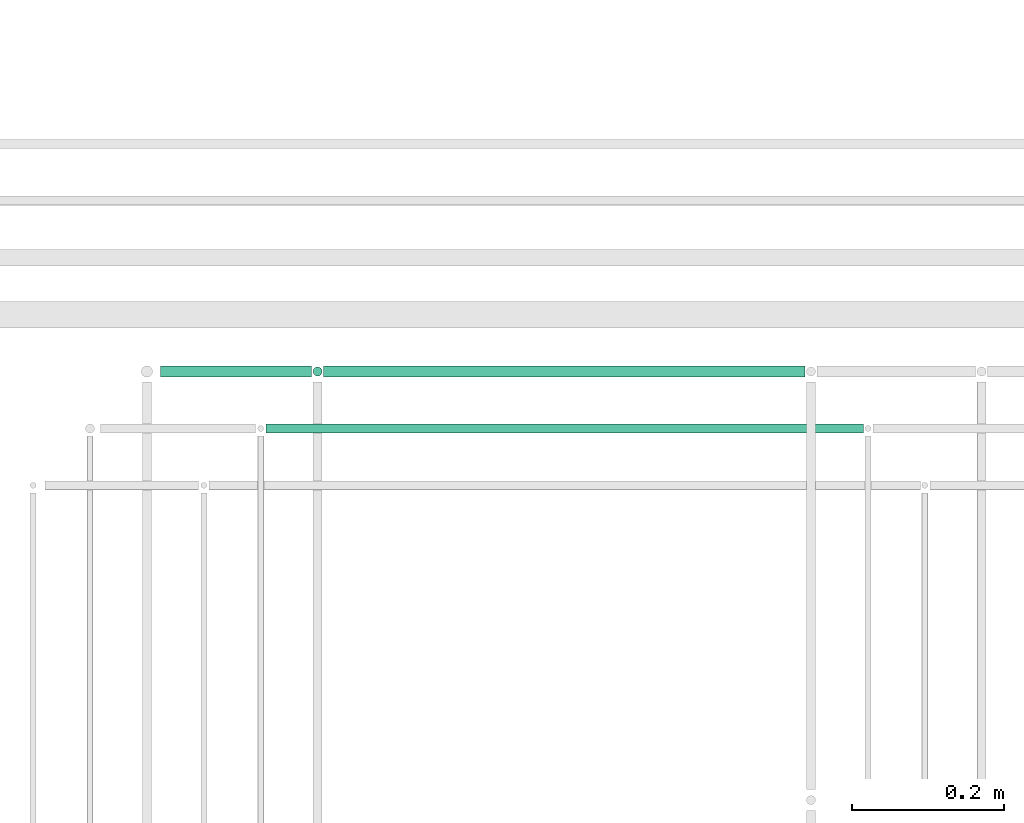
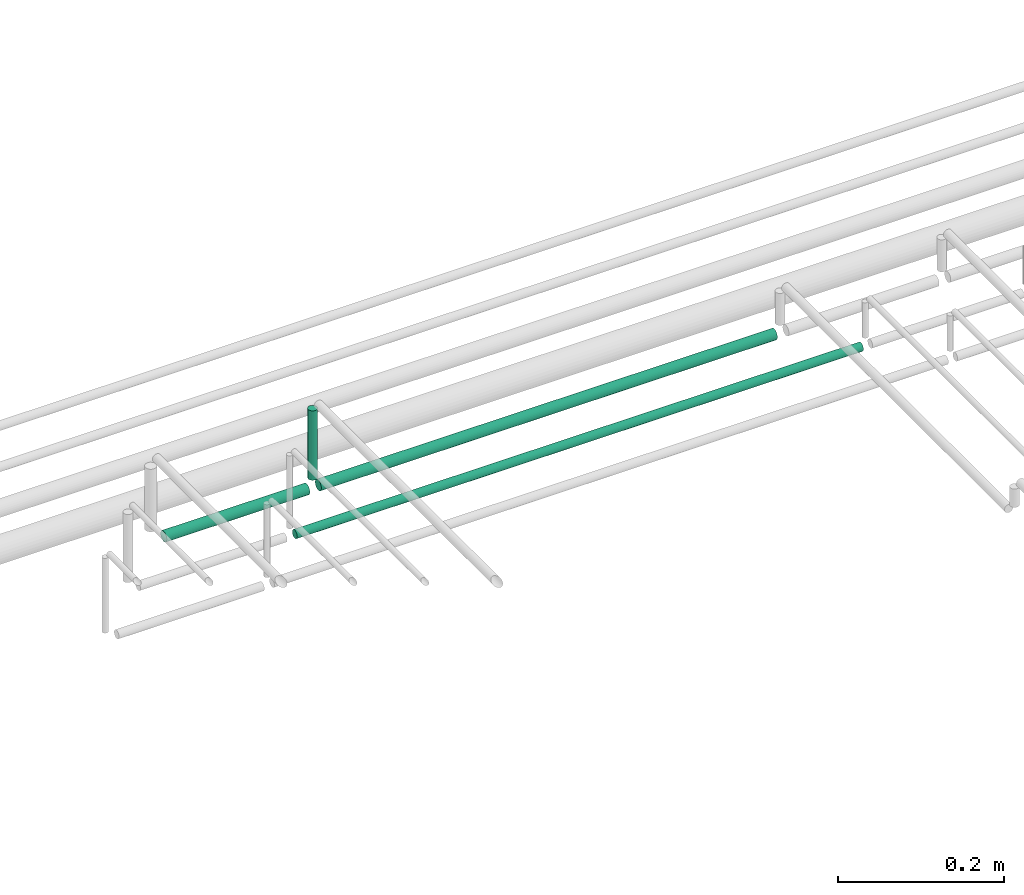
# One storey, part 190 of 331: 4 flow segments.
"""IFC2X3 building model written with IfcOpenShell, lengths in millimetres."""

from ifc_helpers import new_model, entity, si_unit, converted_unit, derived_unit, direction, frame, frame_2d, origin, origin_2d_with_axis, place, context, subcontext, project, spatial, circle, extrude, type_object, element, save


model = new_model("IFC2X3")

# Units and contexts
model_context = context("Model", 3, precision=0.01, world=origin(), true_north=direction((6.12303176911189e-17, 1.0)))
body_context = subcontext(model_context, "Body", "Model", "MODEL_VIEW")
ifc_project = project(units=[si_unit("LENGTHUNIT", "METRE", prefix="MILLI"), si_unit("AREAUNIT", "SQUARE_METRE"), si_unit("VOLUMEUNIT", "CUBIC_METRE"), converted_unit("PLANEANGLEUNIT", "DEGREE", entity("IfcRatioMeasure", 0.0174532925199433), si_unit("PLANEANGLEUNIT", "RADIAN"), dimensions=[0, 0, 0, 0, 0, 0, 0]), si_unit("MASSUNIT", "GRAM", prefix="KILO"), derived_unit("MASSDENSITYUNIT", [(si_unit("MASSUNIT", "GRAM", prefix="KILO"), 1), (si_unit("LENGTHUNIT", "METRE"), -3)]), derived_unit("MOMENTOFINERTIAUNIT", [(si_unit("LENGTHUNIT", "METRE"), 4)]), si_unit("TIMEUNIT", "SECOND"), si_unit("FREQUENCYUNIT", "HERTZ"), si_unit("THERMODYNAMICTEMPERATUREUNIT", "DEGREE_CELSIUS"), derived_unit("THERMALTRANSMITTANCEUNIT", [(si_unit("MASSUNIT", "GRAM", prefix="KILO"), 1), (si_unit("THERMODYNAMICTEMPERATUREUNIT", "KELVIN"), -1), (si_unit("TIMEUNIT", "SECOND"), -3)]), derived_unit("VOLUMETRICFLOWRATEUNIT", [(si_unit("LENGTHUNIT", "METRE"), 3), (si_unit("TIMEUNIT", "SECOND"), -1)]), derived_unit("MASSFLOWRATEUNIT", [(si_unit("MASSUNIT", "GRAM", prefix="KILO"), 1), (si_unit("TIMEUNIT", "SECOND"), -1)]), derived_unit("ROTATIONALFREQUENCYUNIT", [(si_unit("TIMEUNIT", "SECOND"), -1)]), si_unit("ELECTRICCURRENTUNIT", "AMPERE"), si_unit("ELECTRICVOLTAGEUNIT", "VOLT"), si_unit("POWERUNIT", "WATT"), si_unit("FORCEUNIT", "NEWTON", prefix="KILO"), si_unit("ILLUMINANCEUNIT", "LUX"), si_unit("LUMINOUSFLUXUNIT", "LUMEN"), si_unit("LUMINOUSINTENSITYUNIT", "CANDELA"), derived_unit("USERDEFINED", [(si_unit("MASSUNIT", "GRAM", prefix="KILO"), -1), (si_unit("LENGTHUNIT", "METRE"), -2), (si_unit("TIMEUNIT", "SECOND"), 3), (si_unit("LUMINOUSFLUXUNIT", "LUMEN"), 1)]), derived_unit("LINEARVELOCITYUNIT", [(si_unit("LENGTHUNIT", "METRE"), 1), (si_unit("TIMEUNIT", "SECOND"), -1)]), si_unit("PRESSUREUNIT", "PASCAL"), derived_unit("USERDEFINED", [(si_unit("LENGTHUNIT", "METRE"), -2), (si_unit("MASSUNIT", "GRAM", prefix="KILO"), 1), (si_unit("TIMEUNIT", "SECOND"), -2)]), derived_unit("LINEARFORCEUNIT", [(si_unit("MASSUNIT", "GRAM", prefix="KILO"), 1), (si_unit("LENGTHUNIT", "METRE"), 1), (si_unit("TIMEUNIT", "SECOND"), -2), (si_unit("LENGTHUNIT", "METRE"), -1)]), derived_unit("PLANARFORCEUNIT", [(si_unit("MASSUNIT", "GRAM", prefix="KILO"), 1), (si_unit("LENGTHUNIT", "METRE"), 1), (si_unit("TIMEUNIT", "SECOND"), -2), (si_unit("LENGTHUNIT", "METRE"), -2)])], contexts=[model_context])

# Site, building, storey
site_placement = place(None, frame((0.0, -0.00077364408347762, 0.0)))
site = spatial("IfcSite", under=ifc_project, at=site_placement, CompositionType="ELEMENT")
building_placement = place(site_placement, origin())
building = spatial("IfcBuilding", under=site, at=building_placement, CompositionType="ELEMENT")
storey_placement = place(building_placement, origin())
storey = spatial("IfcBuildingStorey", under=building, at=storey_placement, CompositionType="ELEMENT", Elevation=0.0)

# Flow segments
pipe_segment_type = type_object("IfcPipeSegmentType", PredefinedType="NOTDEFINED")
flow_segment_1_placement = place(storey_placement, frame((43777.0420767625, 9467.40472776405, 18442.4047277642)))
element("IfcFlowSegment", 1, at=flow_segment_1_placement, inside=storey, type_object=pipe_segment_type, context=body_context, shape_type="SweptSolid", body=[
    extrude(circle(Radius=6.0, at=frame_2d((1.08286712929839e-12, 0.0), x_axis=(1.0, 0.0))), frame((0.0, 7.5952722359167, 7.5952722359167), z_axis=(1.0, 0.0, 0.0), x_axis=(0.0, 1.0, 0.0)), (0.0, 0.0, 1.0), 787.286850831142),
])
flow_segment_2_placement = place(storey_placement, frame((43853.0420767625, 9540.90472776404, 18440.9047277642)))
element("IfcFlowSegment", 2, at=flow_segment_2_placement, inside=storey, type_object=pipe_segment_type, context=body_context, shape_type="SweptSolid", body=[
    extrude(circle(Radius=7.5, at=origin_2d_with_axis()), frame((0.0, 9.09527223591636, 9.09527223591636), z_axis=(1.0, 0.0, 0.0), x_axis=(0.0, -1.0, 0.0)), (0.0, 0.0, 1.0), 634.123843610235),
])
flow_segment_3_placement = place(building_placement, frame((43837.4468045266, 9542.40472776404, 18464.0)))
element("IfcFlowSegment", 3, at=flow_segment_3_placement, inside=storey, type_object=pipe_segment_type, context=body_context, shape_type="SweptSolid", body=[
    extrude(circle(Radius=6.0, at=origin_2d_with_axis()), frame((7.59527223591454, 7.59527223591562, 0.0), z_axis=(0.0, 0.0, 1.0), x_axis=(-1.0, 0.0, 0.0)), (0.0, 0.0, 1.0), 101.999999999981),
])
flow_segment_4_placement = place(storey_placement, frame((43638.0420767625, 9540.90472776404, 18440.9047277641)))
element("IfcFlowSegment", 4, at=flow_segment_4_placement, inside=storey, type_object=pipe_segment_type, context=body_context, shape_type="SweptSolid", body=[
    extrude(circle(Radius=7.5, at=origin_2d_with_axis()), frame((0.0, 9.09527223591636, 9.09527223591636), z_axis=(1.0, 0.0, 0.0), x_axis=(0.0, -1.0, 0.0)), (0.0, 0.0, 1.0), 198.999999999998),
])

save(model, "model.ifc")
